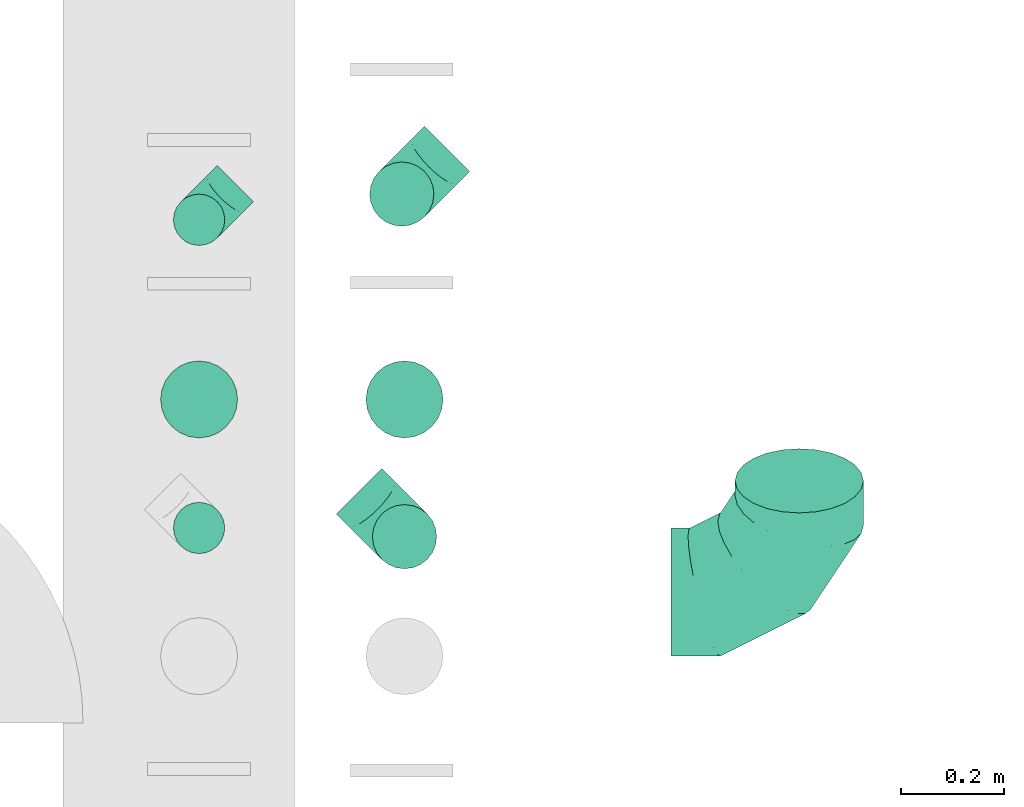
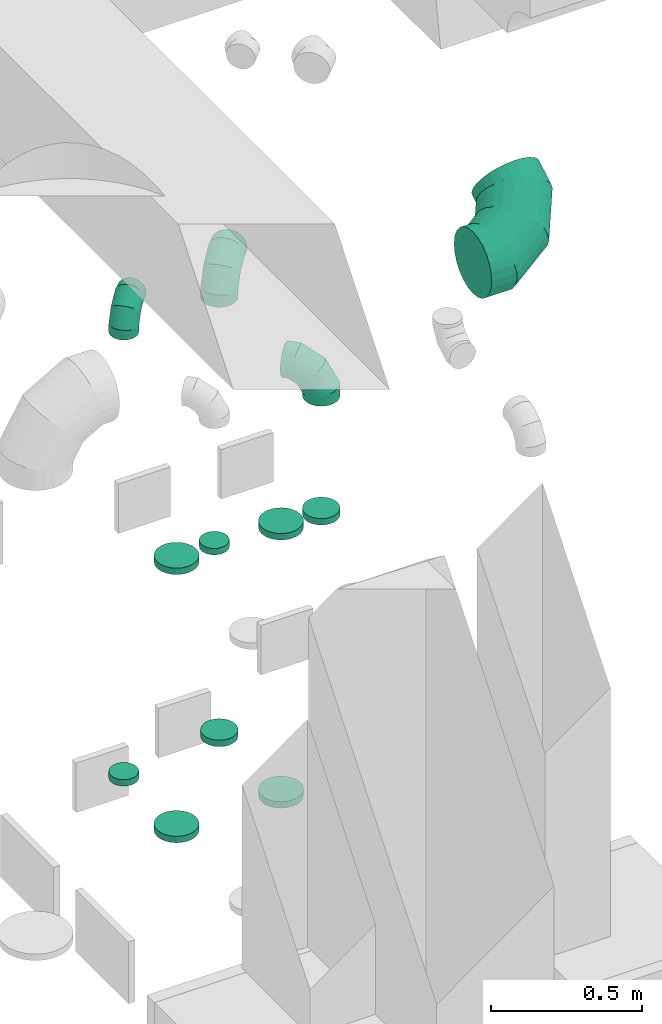
# One storey, part 36 of 59: 12 flow fittings.
"""IFC2X3 building model written with IfcOpenShell, lengths in millimetres."""

from ifc_helpers import new_model, entity, si_unit, converted_unit, derived_unit, direction, frame, origin, place, context, subcontext, project, spatial, faceted_brep, source, transform, mapped, material, type_object, type_shapes, element, save


model = new_model("IFC2X3")

# Units and contexts
model_context = context("Model", 3, precision=0.01, world=origin(), true_north=direction((6.12303176911189e-17, 1.0)))
body_context = subcontext(model_context, "Body", "Model", "MODEL_VIEW")
ifc_project = project(units=[si_unit("LENGTHUNIT", "METRE", prefix="MILLI"), si_unit("AREAUNIT", "SQUARE_METRE"), si_unit("VOLUMEUNIT", "CUBIC_METRE"), converted_unit("PLANEANGLEUNIT", "DEGREE", entity("IfcRatioMeasure", 0.0174532925199433), si_unit("PLANEANGLEUNIT", "RADIAN"), dimensions=[0, 0, 0, 0, 0, 0, 0]), si_unit("MASSUNIT", "GRAM", prefix="KILO"), derived_unit("MASSDENSITYUNIT", [(si_unit("MASSUNIT", "GRAM", prefix="KILO"), 1), (si_unit("LENGTHUNIT", "METRE"), -3)]), derived_unit("MOMENTOFINERTIAUNIT", [(si_unit("LENGTHUNIT", "METRE"), 4)]), si_unit("TIMEUNIT", "SECOND"), si_unit("FREQUENCYUNIT", "HERTZ"), si_unit("THERMODYNAMICTEMPERATUREUNIT", "DEGREE_CELSIUS"), derived_unit("THERMALTRANSMITTANCEUNIT", [(si_unit("MASSUNIT", "GRAM", prefix="KILO"), 1), (si_unit("THERMODYNAMICTEMPERATUREUNIT", "KELVIN"), -1), (si_unit("TIMEUNIT", "SECOND"), -3)]), derived_unit("VOLUMETRICFLOWRATEUNIT", [(si_unit("LENGTHUNIT", "METRE"), 3), (si_unit("TIMEUNIT", "SECOND"), -1)]), derived_unit("MASSFLOWRATEUNIT", [(si_unit("MASSUNIT", "GRAM", prefix="KILO"), 1), (si_unit("TIMEUNIT", "SECOND"), -1)]), derived_unit("ROTATIONALFREQUENCYUNIT", [(si_unit("TIMEUNIT", "SECOND"), -1)]), si_unit("ELECTRICCURRENTUNIT", "AMPERE"), si_unit("ELECTRICVOLTAGEUNIT", "VOLT"), si_unit("POWERUNIT", "WATT"), si_unit("FORCEUNIT", "NEWTON", prefix="KILO"), si_unit("ILLUMINANCEUNIT", "LUX"), si_unit("LUMINOUSFLUXUNIT", "LUMEN"), si_unit("LUMINOUSINTENSITYUNIT", "CANDELA"), derived_unit("USERDEFINED", [(si_unit("MASSUNIT", "GRAM", prefix="KILO"), -1), (si_unit("LENGTHUNIT", "METRE"), -2), (si_unit("TIMEUNIT", "SECOND"), 3), (si_unit("LUMINOUSFLUXUNIT", "LUMEN"), 1)]), derived_unit("LINEARVELOCITYUNIT", [(si_unit("LENGTHUNIT", "METRE"), 1), (si_unit("TIMEUNIT", "SECOND"), -1)]), si_unit("PRESSUREUNIT", "PASCAL"), derived_unit("USERDEFINED", [(si_unit("LENGTHUNIT", "METRE"), -2), (si_unit("MASSUNIT", "GRAM", prefix="KILO"), 1), (si_unit("TIMEUNIT", "SECOND"), -2)]), derived_unit("LINEARFORCEUNIT", [(si_unit("MASSUNIT", "GRAM", prefix="KILO"), 1), (si_unit("LENGTHUNIT", "METRE"), 1), (si_unit("TIMEUNIT", "SECOND"), -2), (si_unit("LENGTHUNIT", "METRE"), -1)]), derived_unit("PLANARFORCEUNIT", [(si_unit("MASSUNIT", "GRAM", prefix="KILO"), 1), (si_unit("LENGTHUNIT", "METRE"), 1), (si_unit("TIMEUNIT", "SECOND"), -2), (si_unit("LENGTHUNIT", "METRE"), -2)])], contexts=[model_context])

# Site, building, storey
site_placement = place(None, origin())
site = spatial("IfcSite", under=ifc_project, at=site_placement, CompositionType="ELEMENT")
building_placement = place(site_placement, origin())
building = spatial("IfcBuilding", under=site, at=building_placement, CompositionType="ELEMENT")
storey_placement = place(building_placement, frame((0.0, 0.0, 28200.0)))
storey = spatial("IfcBuildingStorey", under=building, at=storey_placement, CompositionType="ELEMENT", Elevation=28200.0)

# Flow fittings
ifc_material = material()
duct_fitting_type_1 = type_object("IfcDuctFittingType", PredefinedType="NOTDEFINED", material=ifc_material)
shared_shape_1 = source(origin(), body_context, "Body", "Brep", [
    faceted_brep([(-100.0, 0.0, -50.0), (-100.0, -12.94, -48.3), (-100.0, -25.0, -43.3), (-100.0, -35.36, -35.36), (-100.0, -43.3, -25.0), (-100.0, -48.3, -12.94), (-100.0, -50.0, 0.0), (-100.0, -48.3, 12.94), (-100.0, -43.3, 25.0), (-100.0, -35.36, 35.36), (-100.0, -25.0, 43.3), (-100.0, -12.94, 48.3), (-100.0, 0.0, 50.0), (-100.0, 12.94, 48.3), (-100.0, 25.0, 43.3), (-100.0, 35.36, 35.36), (-100.0, 43.3, 25.0), (-100.0, 48.3, 12.94), (-100.0, 50.0, 0.0), (-100.0, 48.3, -12.94), (-100.0, 43.3, -25.0), (-100.0, 35.36, -35.36), (-100.0, 25.0, -43.3), (-100.0, 12.94, -48.3), (-76.67, 12.94, 48.3), (-79.9, 25.0, 43.3), (-73.21, 0.0, 50.0), (-82.68, 35.36, 35.36), (-86.15, 48.3, 12.94), (-86.6, 50.0, 0.0), (-84.81, 43.3, 25.0), (-84.81, 43.3, -25.0), (-82.68, 35.36, -35.36), (-86.15, 48.3, -12.94), (-76.67, 12.94, -48.3), (-73.21, 0.0, -50.0), (-79.9, 25.0, -43.3), (-69.74, -12.94, -48.3), (-66.51, -25.0, -43.3), (-63.73, -35.36, -35.36), (-61.6, -43.3, -25.0), (-60.26, -48.3, -12.94), (-59.81, -50.0, 0.0), (-60.26, -48.3, 12.94), (-61.6, -43.3, 25.0), (-63.73, -35.36, 35.36), (-66.51, -25.0, 43.3), (-69.74, -12.94, 48.3), (-36.27, 36.27, 48.3), (-45.1, 45.1, 43.3), (-26.79, 26.79, 50.0), (-52.68, 52.68, 35.36), (-58.49, 58.49, 25.0), (-62.15, 62.15, 12.94), (-63.4, 63.4, 0.0), (-62.15, 62.15, -12.94), (-58.49, 58.49, -25.0), (-52.68, 52.68, -35.36), (-36.27, 36.27, -48.3), (-26.79, 26.79, -50.0), (-45.1, 45.1, -43.3), (-17.32, 17.32, -48.3), (-8.49, 8.49, -43.3), (-0.91, 0.91, -35.36), (4.9, -4.9, -25.0), (8.56, -8.56, -12.94), (9.81, -9.81, 0.0), (8.56, -8.56, 12.94), (4.9, -4.9, 25.0), (-0.91, 0.91, 35.36), (-8.49, 8.49, 43.3), (-17.32, 17.32, 48.3), (-12.94, 76.67, 48.3), (-25.0, 79.9, 43.3), (0.0, 73.21, 50.0), (-35.36, 82.68, 35.36), (-43.3, 84.81, 25.0), (-48.3, 86.15, 12.94), (-50.0, 86.6, 0.0), (-48.3, 86.15, -12.94), (-43.3, 84.81, -25.0), (-35.36, 82.68, -35.36), (-12.94, 76.67, -48.3), (0.0, 73.21, -50.0), (-25.0, 79.9, -43.3), (12.94, 69.74, -48.3), (25.0, 66.51, -43.3), (35.36, 63.73, -35.36), (43.3, 61.6, -25.0), (48.3, 60.26, -12.94), (50.0, 59.81, 0.0), (48.3, 60.26, 12.94), (43.3, 61.6, 25.0), (35.36, 63.73, 35.36), (25.0, 66.51, 43.3), (12.94, 69.74, 48.3), (-12.94, 100.0, -48.3), (-25.0, 100.0, -43.3), (-35.36, 100.0, -35.36), (-43.3, 100.0, -25.0), (-48.3, 100.0, -12.94), (-50.0, 100.0, 0.0), (-48.3, 100.0, 12.94), (-43.3, 100.0, 25.0), (-35.36, 100.0, 35.36), (-25.0, 100.0, 43.3), (-12.94, 100.0, 48.3), (0.0, 100.0, 50.0), (12.94, 100.0, 48.3), (25.0, 100.0, 43.3), (35.36, 100.0, 35.36), (43.3, 100.0, 25.0), (48.3, 100.0, 12.94), (50.0, 100.0, 0.0), (48.3, 100.0, -12.94), (43.3, 100.0, -25.0), (35.36, 100.0, -35.36), (25.0, 100.0, -43.3), (12.94, 100.0, -48.3), (0.0, 100.0, -50.0)], [[[0, 1, 2, 3, 4, 5, 6, 7, 8, 9, 10, 11, 12, 13, 14, 15, 16, 17, 18, 19, 20, 21, 22, 23]], [[24, 25, 14, 13]], [[26, 24, 13, 12]], [[14, 25, 27, 15]], [[28, 29, 18, 17]], [[30, 28, 17, 16]], [[15, 27, 30, 16]], [[20, 31, 32, 21]], [[33, 31, 20, 19]], [[18, 29, 33, 19]], [[34, 35, 0, 23]], [[36, 34, 23, 22]], [[32, 36, 22, 21]], [[2, 1, 37, 38]], [[3, 2, 38, 39]], [[0, 35, 37, 1]], [[5, 4, 40, 41]], [[6, 5, 41, 42]], [[3, 39, 40, 4]], [[6, 42, 43, 7]], [[7, 43, 44, 8]], [[8, 44, 45, 9]], [[10, 46, 47, 11]], [[11, 47, 26, 12]], [[10, 9, 45, 46]], [[48, 49, 25, 24]], [[50, 48, 24, 26]], [[27, 25, 49, 51]], [[52, 53, 28, 30]], [[51, 52, 30, 27]], [[29, 28, 53, 54]], [[55, 56, 31, 33]], [[54, 55, 33, 29]], [[57, 32, 31, 56]], [[58, 59, 35, 34]], [[60, 58, 34, 36]], [[57, 60, 36, 32]], [[37, 35, 59, 61]], [[38, 37, 61, 62]], [[39, 38, 62, 63]], [[41, 40, 64, 65]], [[42, 41, 65, 66]], [[63, 64, 40, 39]], [[43, 42, 66, 67]], [[44, 43, 67, 68]], [[68, 69, 45, 44]], [[46, 45, 69, 70]], [[47, 46, 70, 71]], [[26, 47, 71, 50]], [[72, 73, 49, 48]], [[74, 72, 48, 50]], [[51, 49, 73, 75]], [[76, 77, 53, 52]], [[75, 76, 52, 51]], [[54, 53, 77, 78]], [[79, 80, 56, 55]], [[78, 79, 55, 54]], [[81, 57, 56, 80]], [[82, 83, 59, 58]], [[84, 82, 58, 60]], [[81, 84, 60, 57]], [[61, 59, 83, 85]], [[62, 61, 85, 86]], [[63, 62, 86, 87]], [[65, 64, 88, 89]], [[66, 65, 89, 90]], [[87, 88, 64, 63]], [[67, 66, 90, 91]], [[68, 67, 91, 92]], [[92, 93, 69, 68]], [[70, 69, 93, 94]], [[71, 70, 94, 95]], [[50, 71, 95, 74]], [[96, 97, 98, 99, 100, 101, 102, 103, 104, 105, 106, 107, 108, 109, 110, 111, 112, 113, 114, 115, 116, 117, 118, 119]], [[72, 74, 107, 106]], [[73, 72, 106, 105]], [[75, 73, 105, 104]], [[77, 76, 103, 102]], [[78, 77, 102, 101]], [[75, 104, 103, 76]], [[78, 101, 100, 79]], [[79, 100, 99, 80]], [[80, 99, 98, 81]], [[96, 119, 83, 82]], [[97, 96, 82, 84]], [[84, 81, 98, 97]], [[83, 119, 118, 85]], [[85, 118, 117, 86]], [[86, 117, 116, 87]], [[88, 115, 114, 89]], [[89, 114, 113, 90]], [[87, 116, 115, 88]], [[91, 90, 113, 112]], [[92, 91, 112, 111]], [[93, 92, 111, 110]], [[95, 94, 109, 108]], [[74, 95, 108, 107]], [[110, 109, 94, 93]]]),
])
type_shapes(duct_fitting_type_1, [shared_shape_1])
flow_fitting_1_placement = place(storey_placement, frame((57136.5, 10462.81, 2300.0), z_axis=(-0.707106781186548, 0.707106781186548, 0.0), x_axis=(0.0, 0.0, 1.0)))
element("IfcFlowFitting", 1, at=flow_fitting_1_placement, inside=storey, type_object=duct_fitting_type_1, material=ifc_material, context=body_context, shape_type="MappedRepresentation", body=[
    mapped(shared_shape_1, transform((0.0, 0.0, 0.0), scale=1.0)),
])
duct_fitting_type_2 = type_object("IfcDuctFittingType", PredefinedType="NOTDEFINED", material=ifc_material)
shared_shape_2 = source(origin(), body_context, "Body", "Brep", [
    faceted_brep([(-250.0, 0.0, -125.0), (-250.0, -32.35, -120.74), (-250.0, -62.5, -108.25), (-250.0, -88.39, -88.39), (-250.0, -108.25, -62.5), (-250.0, -120.74, -32.35), (-250.0, -125.0, 0.0), (-250.0, -120.74, 32.35), (-250.0, -108.25, 62.5), (-250.0, -88.39, 88.39), (-250.0, -62.5, 108.25), (-250.0, -32.35, 120.74), (-250.0, 0.0, 125.0), (-250.0, 32.35, 120.74), (-250.0, 62.5, 108.25), (-250.0, 88.39, 88.39), (-250.0, 108.25, 62.5), (-250.0, 120.74, 32.35), (-250.0, 125.0, 0.0), (-250.0, 120.74, -32.35), (-250.0, 108.25, -62.5), (-250.0, 88.39, -88.39), (-250.0, 62.5, -108.25), (-250.0, 32.35, -120.74), (-191.68, 32.35, 120.74), (-199.76, 62.5, 108.25), (-183.01, 0.0, 125.0), (-206.7, 88.39, 88.39), (-215.37, 120.74, 32.35), (-216.51, 125.0, 0.0), (-212.02, 108.25, 62.5), (-212.02, 108.25, -62.5), (-206.7, 88.39, -88.39), (-215.37, 120.74, -32.35), (-191.68, 32.35, -120.74), (-183.01, 0.0, -125.0), (-199.76, 62.5, -108.25), (-174.34, -32.35, -120.74), (-166.27, -62.5, -108.25), (-159.33, -88.39, -88.39), (-154.01, -108.25, -62.5), (-150.66, -120.74, -32.35), (-149.52, -125.0, 0.0), (-150.66, -120.74, 32.35), (-154.01, -108.25, 62.5), (-159.33, -88.39, 88.39), (-166.27, -62.5, 108.25), (-174.34, -32.35, 120.74), (-90.67, 90.67, 120.74), (-112.74, 112.74, 108.25), (-66.99, 66.99, 125.0), (-131.69, 131.69, 88.39), (-146.23, 146.23, 62.5), (-155.38, 155.38, 32.35), (-158.49, 158.49, 0.0), (-155.38, 155.38, -32.35), (-146.23, 146.23, -62.5), (-131.69, 131.69, -88.39), (-90.67, 90.67, -120.74), (-66.99, 66.99, -125.0), (-112.74, 112.74, -108.25), (-43.3, 43.3, -120.74), (-21.23, 21.23, -108.25), (-2.28, 2.28, -88.39), (12.26, -12.26, -62.5), (21.4, -21.4, -32.35), (24.52, -24.52, 0.0), (21.4, -21.4, 32.35), (12.26, -12.26, 62.5), (-2.28, 2.28, 88.39), (-21.23, 21.23, 108.25), (-43.3, 43.3, 120.74), (-32.35, 191.68, 120.74), (-62.5, 199.76, 108.25), (0.0, 183.01, 125.0), (-88.39, 206.7, 88.39), (-108.25, 212.02, 62.5), (-120.74, 215.37, 32.35), (-125.0, 216.51, 0.0), (-120.74, 215.37, -32.35), (-108.25, 212.02, -62.5), (-88.39, 206.7, -88.39), (-32.35, 191.68, -120.74), (0.0, 183.01, -125.0), (-62.5, 199.76, -108.25), (32.35, 174.34, -120.74), (62.5, 166.27, -108.25), (88.39, 159.33, -88.39), (108.25, 154.01, -62.5), (120.74, 150.66, -32.35), (125.0, 149.52, 0.0), (120.74, 150.66, 32.35), (108.25, 154.01, 62.5), (88.39, 159.33, 88.39), (62.5, 166.27, 108.25), (32.35, 174.34, 120.74), (-32.35, 250.0, -120.74), (-62.5, 250.0, -108.25), (-88.39, 250.0, -88.39), (-108.25, 250.0, -62.5), (-120.74, 250.0, -32.35), (-125.0, 250.0, 0.0), (-120.74, 250.0, 32.35), (-108.25, 250.0, 62.5), (-88.39, 250.0, 88.39), (-62.5, 250.0, 108.25), (-32.35, 250.0, 120.74), (0.0, 250.0, 125.0), (32.35, 250.0, 120.74), (62.5, 250.0, 108.25), (88.39, 250.0, 88.39), (108.25, 250.0, 62.5), (120.74, 250.0, 32.35), (125.0, 250.0, 0.0), (120.74, 250.0, -32.35), (108.25, 250.0, -62.5), (88.39, 250.0, -88.39), (62.5, 250.0, -108.25), (32.35, 250.0, -120.74), (0.0, 250.0, -125.0)], [[[0, 1, 2, 3, 4, 5, 6, 7, 8, 9, 10, 11, 12, 13, 14, 15, 16, 17, 18, 19, 20, 21, 22, 23]], [[24, 25, 14, 13]], [[26, 24, 13, 12]], [[14, 25, 27, 15]], [[28, 29, 18, 17]], [[30, 28, 17, 16]], [[15, 27, 30, 16]], [[20, 31, 32, 21]], [[33, 31, 20, 19]], [[18, 29, 33, 19]], [[34, 35, 0, 23]], [[36, 34, 23, 22]], [[21, 32, 36, 22]], [[1, 0, 35, 37]], [[2, 1, 37, 38]], [[38, 39, 3, 2]], [[5, 4, 40, 41]], [[6, 5, 41, 42]], [[39, 40, 4, 3]], [[6, 42, 43, 7]], [[7, 43, 44, 8]], [[8, 44, 45, 9]], [[9, 45, 46, 10]], [[10, 46, 47, 11]], [[26, 12, 11, 47]], [[48, 49, 25, 24]], [[50, 48, 24, 26]], [[27, 25, 49, 51]], [[52, 53, 28, 30]], [[51, 52, 30, 27]], [[29, 28, 53, 54]], [[55, 56, 31, 33]], [[54, 55, 33, 29]], [[32, 31, 56, 57]], [[58, 59, 35, 34]], [[60, 58, 34, 36]], [[57, 60, 36, 32]], [[37, 35, 59, 61]], [[38, 37, 61, 62]], [[39, 38, 62, 63]], [[41, 40, 64, 65]], [[42, 41, 65, 66]], [[63, 64, 40, 39]], [[43, 42, 66, 67]], [[44, 43, 67, 68]], [[68, 69, 45, 44]], [[46, 45, 69, 70]], [[47, 46, 70, 71]], [[26, 47, 71, 50]], [[72, 73, 49, 48]], [[74, 72, 48, 50]], [[51, 49, 73, 75]], [[76, 77, 53, 52]], [[75, 76, 52, 51]], [[54, 53, 77, 78]], [[79, 80, 56, 55]], [[78, 79, 55, 54]], [[57, 56, 80, 81]], [[82, 83, 59, 58]], [[84, 82, 58, 60]], [[81, 84, 60, 57]], [[61, 59, 83, 85]], [[62, 61, 85, 86]], [[63, 62, 86, 87]], [[65, 64, 88, 89]], [[66, 65, 89, 90]], [[87, 88, 64, 63]], [[67, 66, 90, 91]], [[68, 67, 91, 92]], [[92, 93, 69, 68]], [[70, 69, 93, 94]], [[71, 70, 94, 95]], [[50, 71, 95, 74]], [[96, 97, 98, 99, 100, 101, 102, 103, 104, 105, 106, 107, 108, 109, 110, 111, 112, 113, 114, 115, 116, 117, 118, 119]], [[72, 74, 107, 106]], [[73, 72, 106, 105]], [[75, 73, 105, 104]], [[77, 76, 103, 102]], [[78, 77, 102, 101]], [[75, 104, 103, 76]], [[78, 101, 100, 79]], [[79, 100, 99, 80]], [[80, 99, 98, 81]], [[84, 97, 96, 82]], [[82, 96, 119, 83]], [[84, 81, 98, 97]], [[83, 119, 118, 85]], [[85, 118, 117, 86]], [[116, 87, 86, 117]], [[88, 115, 114, 89]], [[89, 114, 113, 90]], [[115, 88, 87, 116]], [[91, 90, 113, 112]], [[92, 91, 112, 111]], [[111, 110, 93, 92]], [[95, 94, 109, 108]], [[74, 95, 108, 107]], [[110, 109, 94, 93]]]),
])
type_shapes(duct_fitting_type_2, [shared_shape_2])
flow_fitting_2_placement = place(storey_placement, frame((58305.03, 9738.12, 2597.2), z_axis=(0.0, -0.500000000000005, 0.866025403784436), x_axis=(1.0, 0.0, 0.0)))
element("IfcFlowFitting", 2, at=flow_fitting_2_placement, inside=storey, type_object=duct_fitting_type_2, material=ifc_material, context=body_context, shape_type="MappedRepresentation", body=[
    mapped(shared_shape_2, transform((0.0, 0.0, 0.0), scale=1.0)),
])
duct_fitting_type_3 = type_object("IfcDuctFittingType", PredefinedType="NOTDEFINED", material=ifc_material)
shared_shape_3 = source(origin(), body_context, "Body", "Brep", [
    faceted_brep([(-125.0, 0.0, -62.5), (-125.0, -16.18, -60.37), (-125.0, -31.25, -54.13), (-125.0, -44.19, -44.19), (-125.0, -54.13, -31.25), (-125.0, -60.37, -16.18), (-125.0, -62.5, 0.0), (-125.0, -60.37, 16.18), (-125.0, -54.13, 31.25), (-125.0, -44.19, 44.19), (-125.0, -31.25, 54.13), (-125.0, -16.18, 60.37), (-125.0, 0.0, 62.5), (-125.0, 16.18, 60.37), (-125.0, 31.25, 54.13), (-125.0, 44.19, 44.19), (-125.0, 54.13, 31.25), (-125.0, 60.37, 16.18), (-125.0, 62.5, 0.0), (-125.0, 60.37, -16.18), (-125.0, 54.13, -31.25), (-125.0, 44.19, -44.19), (-125.0, 31.25, -54.13), (-125.0, 16.18, -60.37), (-95.84, 16.18, 60.37), (-99.88, 31.25, 54.13), (-91.51, 0.0, 62.5), (-103.35, 44.19, 44.19), (-107.68, 60.37, 16.18), (-108.25, 62.5, 0.0), (-106.01, 54.13, 31.25), (-106.01, 54.13, -31.25), (-103.35, 44.19, -44.19), (-107.68, 60.37, -16.18), (-95.84, 16.18, -60.37), (-91.51, 0.0, -62.5), (-99.88, 31.25, -54.13), (-87.17, -16.18, -60.37), (-83.13, -31.25, -54.13), (-79.66, -44.19, -44.19), (-77.0, -54.13, -31.25), (-75.33, -60.37, -16.18), (-74.76, -62.5, 0.0), (-75.33, -60.37, 16.18), (-77.0, -54.13, 31.25), (-79.66, -44.19, 44.19), (-83.13, -31.25, 54.13), (-87.17, -16.18, 60.37), (-45.34, 45.34, 60.37), (-56.37, 56.37, 54.13), (-33.49, 33.49, 62.5), (-65.85, 65.85, 44.19), (-73.12, 73.12, 31.25), (-77.69, 77.69, 16.18), (-79.25, 79.25, 0.0), (-77.69, 77.69, -16.18), (-73.12, 73.12, -31.25), (-65.85, 65.85, -44.19), (-45.34, 45.34, -60.37), (-33.49, 33.49, -62.5), (-56.37, 56.37, -54.13), (-21.65, 21.65, -60.37), (-10.62, 10.62, -54.13), (-1.14, 1.14, -44.19), (6.13, -6.13, -31.25), (10.7, -10.7, -16.18), (12.26, -12.26, 0.0), (10.7, -10.7, 16.18), (6.13, -6.13, 31.25), (-1.14, 1.14, 44.19), (-10.62, 10.62, 54.13), (-21.65, 21.65, 60.37), (-16.18, 95.84, 60.37), (-31.25, 99.88, 54.13), (0.0, 91.51, 62.5), (-44.19, 103.35, 44.19), (-54.13, 106.01, 31.25), (-60.37, 107.68, 16.18), (-62.5, 108.25, 0.0), (-60.37, 107.68, -16.18), (-54.13, 106.01, -31.25), (-44.19, 103.35, -44.19), (-16.18, 95.84, -60.37), (0.0, 91.51, -62.5), (-31.25, 99.88, -54.13), (16.18, 87.17, -60.37), (31.25, 83.13, -54.13), (44.19, 79.66, -44.19), (54.13, 77.0, -31.25), (60.37, 75.33, -16.18), (62.5, 74.76, 0.0), (60.37, 75.33, 16.18), (54.13, 77.0, 31.25), (44.19, 79.66, 44.19), (31.25, 83.13, 54.13), (16.18, 87.17, 60.37), (-16.18, 125.0, -60.37), (-31.25, 125.0, -54.13), (-44.19, 125.0, -44.19), (-54.13, 125.0, -31.25), (-60.37, 125.0, -16.18), (-62.5, 125.0, 0.0), (-60.37, 125.0, 16.18), (-54.13, 125.0, 31.25), (-44.19, 125.0, 44.19), (-31.25, 125.0, 54.13), (-16.18, 125.0, 60.37), (0.0, 125.0, 62.5), (16.18, 125.0, 60.37), (31.25, 125.0, 54.13), (44.19, 125.0, 44.19), (54.13, 125.0, 31.25), (60.37, 125.0, 16.18), (62.5, 125.0, 0.0), (60.37, 125.0, -16.18), (54.13, 125.0, -31.25), (44.19, 125.0, -44.19), (31.25, 125.0, -54.13), (16.18, 125.0, -60.37), (0.0, 125.0, -62.5)], [[[0, 1, 2, 3, 4, 5, 6, 7, 8, 9, 10, 11, 12, 13, 14, 15, 16, 17, 18, 19, 20, 21, 22, 23]], [[24, 25, 14, 13]], [[26, 24, 13, 12]], [[14, 25, 27, 15]], [[28, 29, 18, 17]], [[30, 28, 17, 16]], [[15, 27, 30, 16]], [[20, 31, 32, 21]], [[33, 31, 20, 19]], [[18, 29, 33, 19]], [[34, 35, 0, 23]], [[36, 34, 23, 22]], [[21, 32, 36, 22]], [[1, 0, 35, 37]], [[2, 1, 37, 38]], [[38, 39, 3, 2]], [[5, 4, 40, 41]], [[6, 5, 41, 42]], [[39, 40, 4, 3]], [[6, 42, 43, 7]], [[7, 43, 44, 8]], [[45, 9, 8, 44]], [[9, 45, 46, 10]], [[10, 46, 47, 11]], [[26, 12, 11, 47]], [[48, 49, 25, 24]], [[50, 48, 24, 26]], [[27, 25, 49, 51]], [[52, 53, 28, 30]], [[51, 52, 30, 27]], [[29, 28, 53, 54]], [[55, 56, 31, 33]], [[54, 55, 33, 29]], [[57, 32, 31, 56]], [[58, 59, 35, 34]], [[60, 58, 34, 36]], [[57, 60, 36, 32]], [[37, 35, 59, 61]], [[38, 37, 61, 62]], [[39, 38, 62, 63]], [[41, 40, 64, 65]], [[42, 41, 65, 66]], [[63, 64, 40, 39]], [[43, 42, 66, 67]], [[44, 43, 67, 68]], [[68, 69, 45, 44]], [[46, 45, 69, 70]], [[47, 46, 70, 71]], [[26, 47, 71, 50]], [[72, 73, 49, 48]], [[74, 72, 48, 50]], [[51, 49, 73, 75]], [[76, 77, 53, 52]], [[75, 76, 52, 51]], [[54, 53, 77, 78]], [[79, 80, 56, 55]], [[78, 79, 55, 54]], [[81, 57, 56, 80]], [[82, 83, 59, 58]], [[84, 82, 58, 60]], [[81, 84, 60, 57]], [[61, 59, 83, 85]], [[62, 61, 85, 86]], [[63, 62, 86, 87]], [[65, 64, 88, 89]], [[66, 65, 89, 90]], [[87, 88, 64, 63]], [[67, 66, 90, 91]], [[68, 67, 91, 92]], [[92, 93, 69, 68]], [[70, 69, 93, 94]], [[71, 70, 94, 95]], [[50, 71, 95, 74]], [[96, 97, 98, 99, 100, 101, 102, 103, 104, 105, 106, 107, 108, 109, 110, 111, 112, 113, 114, 115, 116, 117, 118, 119]], [[72, 74, 107, 106]], [[73, 72, 106, 105]], [[75, 73, 105, 104]], [[77, 76, 103, 102]], [[78, 77, 102, 101]], [[75, 104, 103, 76]], [[78, 101, 100, 79]], [[79, 100, 99, 80]], [[80, 99, 98, 81]], [[96, 119, 83, 82]], [[97, 96, 82, 84]], [[84, 81, 98, 97]], [[83, 119, 118, 85]], [[85, 118, 117, 86]], [[116, 87, 86, 117]], [[88, 115, 114, 89]], [[89, 114, 113, 90]], [[115, 88, 87, 116]], [[91, 90, 113, 112]], [[92, 91, 112, 111]], [[111, 110, 93, 92]], [[95, 94, 109, 108]], [[74, 95, 108, 107]], [[110, 109, 94, 93]]]),
])
type_shapes(duct_fitting_type_3, [shared_shape_3])
for number, where, z_axis, x_axis in (
    (3, (57531.19, 10512.81, 2297.5), (0.707106781186541, -0.707106781186554, 0.0), (-0.707106781186554, -0.707106781186541, 0.0)),
    (4, (57536.5, 9845.81, 2300.0), (0.707106781186546, 0.707106781186549, 0.0), (0.707106781186549, -0.707106781186546, 0.0)),
):
    element("IfcFlowFitting", number, at=place(storey_placement, frame(where, z_axis=z_axis, x_axis=x_axis)), inside=storey, type_object=duct_fitting_type_3, material=ifc_material, context=body_context, shape_type="MappedRepresentation", body=[
        mapped(shared_shape_3, transform((0.0, 0.0, 0.0), scale=1.0)),
    ])
duct_fitting_type_4 = type_object("IfcDuctFittingType", PredefinedType="NOTDEFINED", material=ifc_material)
shared_shape_4 = source(origin(), body_context, "Body", "Brep", [
    faceted_brep([(20.0, 0.0, -62.5), (20.0, 16.18, -60.37), (20.0, 31.25, -54.13), (20.0, 44.19, -44.19), (20.0, 54.13, -31.25), (20.0, 60.37, -16.18), (20.0, 62.5, 0.0), (20.0, 60.37, 16.18), (20.0, 54.13, 31.25), (20.0, 44.19, 44.19), (20.0, 31.25, 54.13), (20.0, 16.18, 60.37), (20.0, 0.0, 62.5), (20.0, -16.18, 60.37), (20.0, -31.25, 54.13), (20.0, -44.19, 44.19), (20.0, -54.13, 31.25), (20.0, -60.37, 16.18), (20.0, -62.5, 0.0), (20.0, -60.37, -16.18), (20.0, -54.13, -31.25), (20.0, -44.19, -44.19), (20.0, -31.25, -54.13), (20.0, -16.18, -60.37), (0.0, 0.0, 62.5), (-6.1, 0.0, 62.5), (-6.1, -16.18, 60.37), (0.0, -16.18, 60.37), (-6.1, -31.25, 54.13), (0.0, -31.25, 54.13), (0.0, -44.19, 44.19), (-6.1, -44.19, 44.19), (0.0, -54.13, 31.25), (-6.1, -54.13, 31.25), (-6.1, -60.37, 16.18), (0.0, -60.37, 16.18), (-6.1, -62.5, 0.0), (0.0, -62.5, 0.0), (-6.1, -60.37, -16.18), (0.0, -60.37, -16.18), (-6.1, -54.13, -31.25), (0.0, -54.13, -31.25), (0.0, -44.19, -44.19), (-6.1, -44.19, -44.19), (0.0, -31.25, -54.13), (-6.1, -31.25, -54.13), (-6.1, -16.18, -60.37), (0.0, -16.18, -60.37), (-6.1, 0.0, -62.5), (0.0, 0.0, -62.5), (-6.1, 16.18, -60.37), (0.0, 16.18, -60.37), (-6.1, 31.25, -54.13), (0.0, 31.25, -54.13), (0.0, 44.19, -44.19), (-6.1, 44.19, -44.19), (0.0, 54.13, -31.25), (-6.1, 54.13, -31.25), (-6.1, 60.37, -16.18), (0.0, 60.37, -16.18), (-6.1, 62.5, 0.0), (0.0, 62.5, 0.0), (-6.1, 60.37, 16.18), (0.0, 60.37, 16.18), (-6.1, 54.13, 31.25), (0.0, 54.13, 31.25), (0.0, 44.19, 44.19), (-6.1, 44.19, 44.19), (0.0, 31.25, 54.13), (-6.1, 31.25, 54.13), (-6.1, 16.18, 60.37), (0.0, 16.18, 60.37)], [[[0, 1, 2, 3, 4, 5, 6, 7, 8, 9, 10, 11, 12, 13, 14, 15, 16, 17, 18, 19, 20, 21, 22, 23]], [[13, 12, 24, 25, 26, 27]], [[14, 13, 27, 26, 28, 29]], [[30, 15, 14, 29, 28, 31]], [[17, 16, 32, 33, 34, 35]], [[18, 17, 35, 34, 36, 37]], [[32, 16, 15, 30, 31, 33]], [[19, 18, 37, 36, 38, 39]], [[20, 19, 39, 38, 40, 41]], [[42, 21, 20, 41, 40, 43]], [[23, 22, 44, 45, 46, 47]], [[0, 23, 47, 46, 48, 49]], [[44, 22, 21, 42, 43, 45]], [[1, 0, 49, 48, 50, 51]], [[2, 1, 51, 50, 52, 53]], [[54, 3, 2, 53, 52, 55]], [[5, 4, 56, 57, 58, 59]], [[6, 5, 59, 58, 60, 61]], [[56, 4, 3, 54, 55, 57]], [[7, 6, 61, 60, 62, 63]], [[8, 7, 63, 62, 64, 65]], [[66, 9, 8, 65, 64, 67]], [[11, 10, 68, 69, 70, 71]], [[12, 11, 71, 70, 25, 24]], [[68, 10, 9, 66, 67, 69]], [[46, 45, 43, 40, 38, 36, 34, 33, 31, 28, 26, 25, 70, 69, 67, 64, 62, 60, 58, 57, 55, 52, 50, 48]]]),
])
type_shapes(duct_fitting_type_4, [shared_shape_4])
for number, where, z_axis, x_axis in (
    (5, (57531.19, 10512.81, 400.0), (0.0, 1.0, 0.0), (0.0, 0.0, 1.0)),
    (6, (57536.5, 9845.81, 1700.0), (0.0, 1.0, 0.0), (0.0, 0.0, 1.0)),
):
    element("IfcFlowFitting", number, at=place(storey_placement, frame(where, z_axis=z_axis, x_axis=x_axis)), inside=storey, type_object=duct_fitting_type_4, material=ifc_material, context=body_context, shape_type="MappedRepresentation", body=[
        mapped(shared_shape_4, transform((0.0, 0.0, 0.0), scale=1.0)),
    ])
duct_fitting_type_5 = type_object("IfcDuctFittingType", PredefinedType="NOTDEFINED", material=ifc_material)
shared_shape_5 = source(origin(), body_context, "Body", "Brep", [
    faceted_brep([(20.0, 0.0, -50.0), (20.0, 12.94, -48.3), (20.0, 25.0, -43.3), (20.0, 35.36, -35.36), (20.0, 43.3, -25.0), (20.0, 48.3, -12.94), (20.0, 50.0, 0.0), (20.0, 48.3, 12.94), (20.0, 43.3, 25.0), (20.0, 35.36, 35.36), (20.0, 25.0, 43.3), (20.0, 12.94, 48.3), (20.0, 0.0, 50.0), (20.0, -12.94, 48.3), (20.0, -25.0, 43.3), (20.0, -35.36, 35.36), (20.0, -43.3, 25.0), (20.0, -48.3, 12.94), (20.0, -50.0, 0.0), (20.0, -48.3, -12.94), (20.0, -43.3, -25.0), (20.0, -35.36, -35.36), (20.0, -25.0, -43.3), (20.0, -12.94, -48.3), (0.0, 0.0, 50.0), (-6.1, 0.0, 50.0), (-6.1, -12.94, 48.3), (0.0, -12.94, 48.3), (-6.1, -25.0, 43.3), (0.0, -25.0, 43.3), (0.0, -35.36, 35.36), (-6.1, -35.36, 35.36), (0.0, -43.3, 25.0), (-6.1, -43.3, 25.0), (-6.1, -48.3, 12.94), (0.0, -48.3, 12.94), (-6.1, -50.0, 0.0), (0.0, -50.0, 0.0), (-6.1, -48.3, -12.94), (0.0, -48.3, -12.94), (-6.1, -43.3, -25.0), (0.0, -43.3, -25.0), (0.0, -35.36, -35.36), (-6.1, -35.36, -35.36), (0.0, -25.0, -43.3), (-6.1, -25.0, -43.3), (-6.1, -12.94, -48.3), (0.0, -12.94, -48.3), (-6.1, 0.0, -50.0), (0.0, 0.0, -50.0), (-6.1, 12.94, -48.3), (0.0, 12.94, -48.3), (-6.1, 25.0, -43.3), (0.0, 25.0, -43.3), (0.0, 35.36, -35.36), (-6.1, 35.36, -35.36), (0.0, 43.3, -25.0), (-6.1, 43.3, -25.0), (-6.1, 48.3, -12.94), (0.0, 48.3, -12.94), (-6.1, 50.0, 0.0), (0.0, 50.0, 0.0), (-6.1, 48.3, 12.94), (0.0, 48.3, 12.94), (-6.1, 43.3, 25.0), (0.0, 43.3, 25.0), (0.0, 35.36, 35.36), (-6.1, 35.36, 35.36), (0.0, 25.0, 43.3), (-6.1, 25.0, 43.3), (-6.1, 12.94, 48.3), (0.0, 12.94, 48.3)], [[[0, 1, 2, 3, 4, 5, 6, 7, 8, 9, 10, 11, 12, 13, 14, 15, 16, 17, 18, 19, 20, 21, 22, 23]], [[13, 12, 24, 25, 26, 27]], [[14, 13, 27, 26, 28, 29]], [[30, 15, 14, 29, 28, 31]], [[17, 16, 32, 33, 34, 35]], [[18, 17, 35, 34, 36, 37]], [[32, 16, 15, 30, 31, 33]], [[19, 18, 37, 36, 38, 39]], [[20, 19, 39, 38, 40, 41]], [[42, 21, 20, 41, 40, 43]], [[23, 22, 44, 45, 46, 47]], [[0, 23, 47, 46, 48, 49]], [[44, 22, 21, 42, 43, 45]], [[1, 0, 49, 48, 50, 51]], [[2, 1, 51, 50, 52, 53]], [[54, 3, 2, 53, 52, 55]], [[5, 4, 56, 57, 58, 59]], [[6, 5, 59, 58, 60, 61]], [[56, 4, 3, 54, 55, 57]], [[7, 6, 61, 60, 62, 63]], [[8, 7, 63, 62, 64, 65]], [[66, 9, 8, 65, 64, 67]], [[11, 10, 68, 69, 70, 71]], [[12, 11, 71, 70, 25, 24]], [[68, 10, 9, 66, 67, 69]], [[46, 45, 43, 40, 38, 36, 34, 33, 31, 28, 26, 25, 70, 69, 67, 64, 62, 60, 58, 57, 55, 52, 50, 48]]]),
])
type_shapes(duct_fitting_type_5, [shared_shape_5])
for number, where, z_axis, x_axis in (
    (7, (57136.5, 9862.81, 1700.0), (0.0, 1.0, 0.0), (0.0, 0.0, 1.0)),
    (8, (57136.5, 10462.81, 400.0), (0.0, 1.0, 0.0), (0.0, 0.0, 1.0)),
):
    element("IfcFlowFitting", number, at=place(storey_placement, frame(where, z_axis=z_axis, x_axis=x_axis)), inside=storey, type_object=duct_fitting_type_5, material=ifc_material, context=body_context, shape_type="MappedRepresentation", body=[
        mapped(shared_shape_5, transform((0.0, 0.0, 0.0), scale=1.0)),
    ])
duct_fitting_type_6 = type_object("IfcDuctFittingType", PredefinedType="NOTDEFINED", material=ifc_material)
shared_shape_6 = source(origin(), body_context, "Body", "Brep", [
    faceted_brep([(20.0, 0.0, -75.0), (20.0, 19.41, -72.44), (20.0, 37.5, -64.95), (20.0, 53.03, -53.03), (20.0, 64.95, -37.5), (20.0, 72.44, -19.41), (20.0, 75.0, 0.0), (20.0, 72.44, 19.41), (20.0, 64.95, 37.5), (20.0, 53.03, 53.03), (20.0, 37.5, 64.95), (20.0, 19.41, 72.44), (20.0, 0.0, 75.0), (20.0, -19.41, 72.44), (20.0, -37.5, 64.95), (20.0, -53.03, 53.03), (20.0, -64.95, 37.5), (20.0, -72.44, 19.41), (20.0, -75.0, 0.0), (20.0, -72.44, -19.41), (20.0, -64.95, -37.5), (20.0, -53.03, -53.03), (20.0, -37.5, -64.95), (20.0, -19.41, -72.44), (0.0, 0.0, 75.0), (-6.1, 0.0, 75.0), (-6.1, -19.41, 72.44), (0.0, -19.41, 72.44), (-6.1, -37.5, 64.95), (0.0, -37.5, 64.95), (0.0, -53.03, 53.03), (-6.1, -53.03, 53.03), (0.0, -64.95, 37.5), (-6.1, -64.95, 37.5), (-6.1, -72.44, 19.41), (0.0, -72.44, 19.41), (-6.1, -75.0, 0.0), (0.0, -75.0, 0.0), (-6.1, -72.44, -19.41), (0.0, -72.44, -19.41), (-6.1, -64.95, -37.5), (0.0, -64.95, -37.5), (0.0, -53.03, -53.03), (-6.1, -53.03, -53.03), (0.0, -37.5, -64.95), (-6.1, -37.5, -64.95), (-6.1, -19.41, -72.44), (0.0, -19.41, -72.44), (-6.1, 0.0, -75.0), (0.0, 0.0, -75.0), (-6.1, 19.41, -72.44), (0.0, 19.41, -72.44), (-6.1, 37.5, -64.95), (0.0, 37.5, -64.95), (0.0, 53.03, -53.03), (-6.1, 53.03, -53.03), (0.0, 64.95, -37.5), (-6.1, 64.95, -37.5), (-6.1, 72.44, -19.41), (0.0, 72.44, -19.41), (-6.1, 75.0, 0.0), (0.0, 75.0, 0.0), (-6.1, 72.44, 19.41), (0.0, 72.44, 19.41), (-6.1, 64.95, 37.5), (0.0, 64.95, 37.5), (0.0, 53.03, 53.03), (-6.1, 53.03, 53.03), (0.0, 37.5, 64.95), (-6.1, 37.5, 64.95), (-6.1, 19.41, 72.44), (0.0, 19.41, 72.44)], [[[0, 1, 2, 3, 4, 5, 6, 7, 8, 9, 10, 11, 12, 13, 14, 15, 16, 17, 18, 19, 20, 21, 22, 23]], [[13, 12, 24, 25, 26, 27]], [[14, 13, 27, 26, 28, 29]], [[30, 15, 14, 29, 28, 31]], [[17, 16, 32, 33, 34, 35]], [[18, 17, 35, 34, 36, 37]], [[32, 16, 15, 30, 31, 33]], [[19, 18, 37, 36, 38, 39]], [[20, 19, 39, 38, 40, 41]], [[42, 21, 20, 41, 40, 43]], [[23, 22, 44, 45, 46, 47]], [[0, 23, 47, 46, 48, 49]], [[44, 22, 21, 42, 43, 45]], [[1, 0, 49, 48, 50, 51]], [[2, 1, 51, 50, 52, 53]], [[54, 3, 2, 53, 52, 55]], [[5, 4, 56, 57, 58, 59]], [[6, 5, 59, 58, 60, 61]], [[56, 4, 3, 54, 55, 57]], [[7, 6, 61, 60, 62, 63]], [[8, 7, 63, 62, 64, 65]], [[66, 9, 8, 65, 64, 67]], [[11, 10, 68, 69, 70, 71]], [[12, 11, 71, 70, 25, 24]], [[68, 10, 9, 66, 67, 69]], [[46, 45, 43, 40, 38, 36, 34, 33, 31, 28, 26, 25, 70, 69, 67, 64, 62, 60, 58, 57, 55, 52, 50, 48]]]),
])
type_shapes(duct_fitting_type_6, [shared_shape_6])
for number, where, z_axis, x_axis in (
    (9, (57136.5, 10113.06, 400.0), (0.0, 1.0, 0.0), (0.0, 0.0, 1.0)),
    (10, (57136.5, 10113.06, 1500.0), (0.0, 1.0, 0.0), (0.0, 0.0, -1.0)),
    (11, (57536.5, 10113.06, 400.0), (0.0, 1.0, 0.0), (0.0, 0.0, 1.0)),
    (12, (57536.5, 10113.06, 1500.0), (0.0, 1.0, 0.0), (0.0, 0.0, -1.0)),
):
    element("IfcFlowFitting", number, at=place(storey_placement, frame(where, z_axis=z_axis, x_axis=x_axis)), inside=storey, type_object=duct_fitting_type_6, material=ifc_material, context=body_context, shape_type="MappedRepresentation", body=[
        mapped(shared_shape_6, transform((0.0, 0.0, 0.0), scale=1.0)),
    ])

save(model, "model.ifc")
